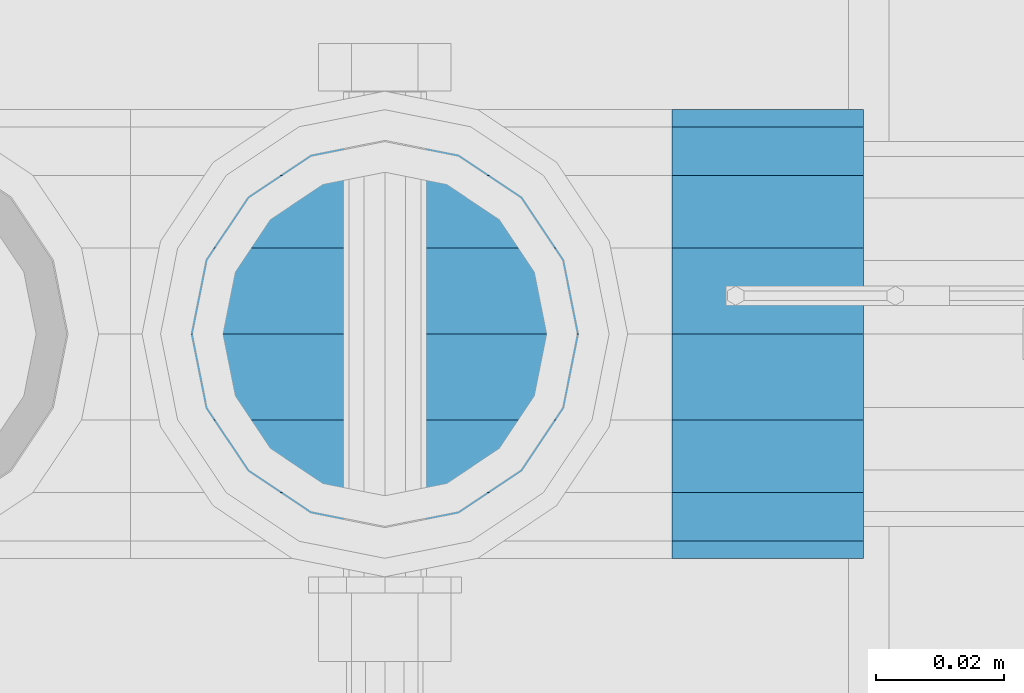
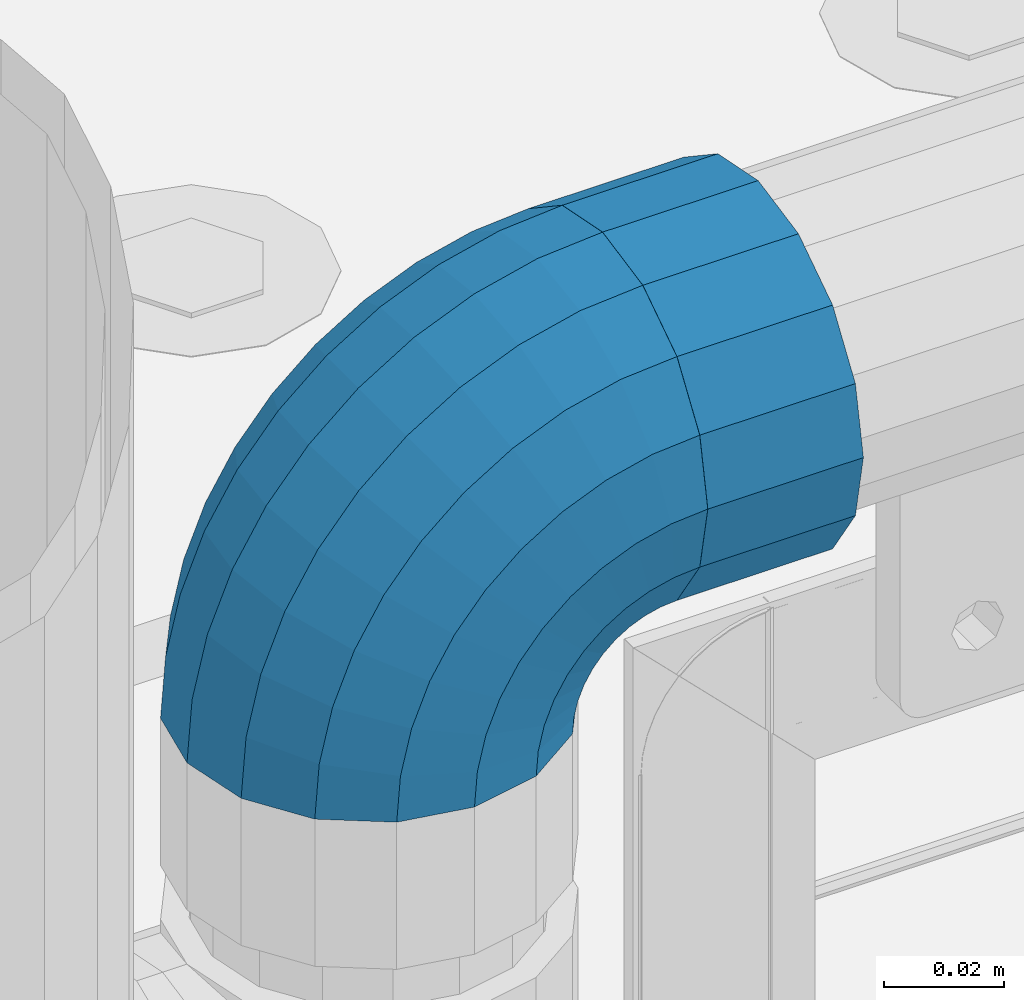
# One storey, part 110 of 193: 1 beam, 1 member.
"""IFC2X3 building model written with IfcOpenShell, lengths in millimetres."""

from ifc_helpers import new_model, si_unit, frame, origin_with_axes, place, context, subcontext, project, spatial, faceted_brep, material, type_object, element, save


model = new_model("IFC2X3")

# Units and contexts
model_context = context("Model", 3, precision=1e-05, world=origin_with_axes())
body_context = subcontext(model_context, "Body", "Model", "MODEL_VIEW")
ifc_project = project(units=[si_unit("LENGTHUNIT", "METRE", prefix="MILLI"), si_unit("AREAUNIT", "SQUARE_METRE"), si_unit("VOLUMEUNIT", "CUBIC_METRE"), si_unit("MASSUNIT", "GRAM", prefix="KILO"), si_unit("TIMEUNIT", "SECOND"), si_unit("PLANEANGLEUNIT", "RADIAN"), si_unit("SOLIDANGLEUNIT", "STERADIAN"), si_unit("THERMODYNAMICTEMPERATUREUNIT", "DEGREE_CELSIUS"), si_unit("LUMINOUSINTENSITYUNIT", "LUMEN")], contexts=[model_context])

# Site, building, storey
site_placement = place(None, origin_with_axes())
site = spatial("IfcSite", under=ifc_project, at=site_placement, CompositionType="ELEMENT")
building_placement = place(site_placement, origin_with_axes())
building = spatial("IfcBuilding", under=site, at=building_placement, Name="Standard", CompositionType="ELEMENT")
storey_placement = place(building_placement, origin_with_axes())
storey = spatial("IfcBuildingStorey", under=building, at=storey_placement, Name="Undefined", CompositionType="ELEMENT", Elevation=0.0)

# Beam
ifc_material = material(Name="Misc_Undefined")
beam_type = type_object("IfcBeamType", PredefinedType="NOTDEFINED")
beam_placement = place(storey_placement, frame((-41784.0, 28664.5, 969.849999999999), z_axis=(0.0, 0.0, 1.0), x_axis=(1.0, 0.0, 0.0)))
element("IfcBeam", 1, at=beam_placement, inside=storey, type_object=beam_type, material=ifc_material, context=body_context, shape_type="Brep", body=[
    faceted_brep([(0.0, -30.3499999999985, 0.0), (0.0, -28.0397438117179, 11.614442172282), (30.0, -28.0397438117179, 11.6144421722805), (30.0, -30.3499999999985, 0.0), (0.0, -21.46069080901, 21.46069080901), (30.0, -21.46069080901, 21.4606908090117), (0.0, -11.614442172282, 28.0397438117179), (30.0, -11.614442172282, 28.0397438117176), (0.0, 0.0, 30.3499999999985), (30.0, 0.0, 30.35), (0.0, 11.614442172282, 28.0397438117179), (30.0, 11.614442172282, 28.0397438117176), (0.0, 21.46069080901, 21.46069080901), (30.0, 21.46069080901, 21.4606908090117), (0.0, 28.0397438117179, 11.614442172282), (30.0, 28.0397438117179, 11.6144421722805), (0.0, 30.3499999999985, 0.0), (30.0, 30.3499999999985, 0.0), (0.0, 28.0397438117179, -11.614442172282), (30.0, 28.0397438117179, -11.6144421722805), (0.0, 21.46069080901, -21.46069080901), (30.0, 21.46069080901, -21.4606908090117), (0.0, 11.614442172282, -28.0397438117179), (30.0, 11.614442172282, -28.0397438117176), (0.0, 0.0, -30.3499999999985), (30.0, 0.0, -30.35), (0.0, -11.614442172282, -28.0397438117179), (30.0, -11.614442172282, -28.0397438117176), (0.0, -21.46069080901, -21.46069080901), (30.0, -21.46069080901, -21.4606908090117), (0.0, -28.0397438117179, -11.614442172282), (30.0, -28.0397438117179, -11.6144421722805), (0.0, -35.1500000000015, 0.0), (0.0, -32.4743655677703, -13.4513226476338), (30.0, -32.4743655677703, -13.4513226476329), (30.0, -35.1500000000015, 0.0), (0.0, -24.8548033587067, -24.8548033587067), (30.0, -24.8548033587067, -24.8548033587072), (0.0, -13.4513226476338, -32.4743655677703), (30.0, -13.4513226476338, -32.4743655677718), (0.0, 0.0, -35.1500000000015), (30.0, 0.0, -35.15), (0.0, 13.4513226476338, -32.4743655677703), (30.0, 13.4513226476338, -32.4743655677718), (0.0, 24.8548033587067, -24.8548033587067), (30.0, 24.8548033587067, -24.8548033587072), (0.0, 32.4743655677703, -13.4513226476338), (30.0, 32.4743655677703, -13.4513226476329), (0.0, 35.1500000000015, 0.0), (30.0, 35.1500000000015, 0.0), (0.0, 32.4743655677703, 13.4513226476338), (30.0, 32.4743655677703, 13.4513226476329), (0.0, 24.8548033587067, 24.8548033587067), (30.0, 24.8548033587067, 24.8548033587072), (0.0, 13.4513226476338, 32.4743655677703), (30.0, 13.4513226476338, 32.4743655677718), (0.0, 0.0, 35.1500000000015), (30.0, 0.0, 35.15), (0.0, -13.4513226476338, 32.4743655677703), (30.0, -13.4513226476338, 32.4743655677718), (0.0, -24.8548033587067, 24.8548033587067), (30.0, -24.8548033587067, 24.8548033587072), (0.0, -32.4743655677703, 13.4513226476338), (30.0, -32.4743655677703, 13.4513226476329)], [[[0, 1, 2, 3]], [[1, 4, 5, 2]], [[4, 6, 7, 5]], [[6, 8, 9, 7]], [[8, 10, 11, 9]], [[10, 12, 13, 11]], [[12, 14, 15, 13]], [[14, 16, 17, 15]], [[16, 18, 19, 17]], [[18, 20, 21, 19]], [[20, 22, 23, 21]], [[22, 24, 25, 23]], [[24, 26, 27, 25]], [[26, 28, 29, 27]], [[28, 30, 31, 29]], [[30, 0, 3, 31]], [[32, 33, 34, 35]], [[33, 36, 37, 34]], [[36, 38, 39, 37]], [[38, 40, 41, 39]], [[40, 42, 43, 41]], [[42, 44, 45, 43]], [[44, 46, 47, 45]], [[46, 48, 49, 47]], [[48, 50, 51, 49]], [[50, 52, 53, 51]], [[52, 54, 55, 53]], [[54, 56, 57, 55]], [[56, 58, 59, 57]], [[58, 60, 61, 59]], [[60, 62, 63, 61]], [[62, 32, 35, 63]], [[37, 39, 41, 43, 45, 47, 49, 51, 53, 55, 57, 59, 61, 63, 35, 34], [5, 7, 9, 11, 13, 15, 17, 19, 21, 23, 25, 27, 29, 31, 3, 2]], [[62, 60, 58, 56, 54, 52, 50, 48, 46, 44, 42, 40, 38, 36, 33, 32], [30, 28, 26, 24, 22, 20, 18, 16, 14, 12, 10, 8, 6, 4, 1, 0]]]),
])

# Member
member_type = type_object("IfcMemberType", PredefinedType="NOTDEFINED")
member_placement = place(storey_placement, frame((-41829.0, 28664.5, 924.849999999999), z_axis=(-0.707106781186548, 0.0, 0.707106781186548), x_axis=(0.707106781186547, 0.0, 0.707106781186548)))
element("IfcMember", 2, at=member_placement, inside=storey, type_object=member_type, material=ifc_material, context=body_context, shape_type="Brep", body=[
    faceted_brep([(0.0, -35.1500000000015, 0.0), (9.51152146007007, -32.4743655677703, -9.51152146007007), (13.2759578763398, -32.4743655677703, -6.2963890252795), (5.36946880023243, -35.1500000000015, 4.58595959347804), (17.5749999999971, -24.8548033587067, -17.5750000000007), (19.978755663109, -24.8548033587067, -15.5219987155651), (22.9628441077002, -13.4513226476338, -22.9628441077002), (24.4574219585229, -13.4513226476338, -21.6863540323939), (24.8548033587067, 0.0, -24.8548033587067), (26.0301204183124, 0.0, -23.850987758804), (22.9628441077002, 13.4513226476338, -22.9628441077002), (24.4574219585229, 13.4513226476338, -21.6863540323939), (17.5749999999971, 24.8548033587067, -17.5750000000007), (19.978755663109, 24.8548033587067, -15.5219987155651), (9.51152146007007, 32.4743655677703, -9.51152146007007), (13.2759578763398, 32.4743655677703, -6.2963890252795), (0.0, 35.1500000000015, 0.0), (5.36946880023243, 35.1500000000015, 4.58595959347804), (-9.51152146007007, 32.4743655677703, 9.51152146007007), (-2.53702027587133, 32.4743655677703, 15.4683082122356), (-17.5750000000007, 24.8548033587067, 17.5750000000007), (-9.23981806264419, 24.8548033587067, 24.6939179025212), (-22.9628441077039, 13.4513226476338, 22.9628441077002), (-13.718484358058, 13.4513226476338, 30.8582732193499), (-24.8548033587103, 0.0, 24.8548033587067), (-15.2911828178476, 0.0, 33.02290694576), (-22.9628441077039, -13.4513226476338, 22.9628441077002), (-13.718484358058, -13.4513226476338, 30.8582732193499), (-17.5750000000007, -24.8548033587067, 17.5750000000007), (-9.23981806264419, -24.8548033587067, 24.6939179025212), (-9.51152146007007, -32.4743655677703, 9.51152146007007), (-2.53702027587133, -32.4743655677703, 15.4683082122356), (0.0, -30.3499999999985, 0.0), (-8.2126508197216, -28.0397438117179, 8.21265081971796), (-1.45732902223972, -28.0397438117179, 13.9822406910389), (5.36946880023243, -30.3499999999985, 4.58595959347804), (-15.1749999999993, -21.46069080901, 15.1749999999993), (-7.24480876131565, -21.46069080901, 21.9480231689959), (-19.827092992, -11.614442172282, 19.827092992), (-11.1118790903529, -11.614442172282, 27.2705888550809), (-21.4606908090136, 0.0, 21.46069080901), (-12.4698136068437, 0.0, 29.139625372758), (-19.827092992, 11.614442172282, 19.827092992), (-11.1118790903529, 11.614442172282, 27.2705888550809), (-15.1749999999993, 21.46069080901, 15.1749999999993), (-7.24480876131565, 21.46069080901, 21.9480231689959), (-8.2126508197216, 28.0397438117179, 8.21265081971796), (-1.45732902223972, 28.0397438117179, 13.9822406910389), (0.0, 30.3499999999985, 0.0), (5.36946880023243, 30.3499999999985, 4.58595959347804), (8.21265081971796, 28.0397438117179, -8.2126508197216), (12.1962666227009, 28.0397438117179, -4.81032150408282), (15.1749999999956, 21.46069080901, -15.1749999999993), (17.9837463617769, 21.46069080901, -12.7761039820398), (19.8270929919963, 11.614442172282, -19.827092992), (21.8508166908177, 11.614442172282, -18.0986696681211), (21.46069080901, 0.0, -21.46069080901), (23.2087512073085, 0.0, -19.9677061858019), (19.8270929919963, -11.614442172282, -19.827092992), (21.8508166908177, -11.614442172282, -18.0986696681211), (15.1749999999956, -21.46069080901, -15.1749999999993), (17.9837463617769, -21.46069080901, -12.7761039820398), (8.21265081971796, -28.0397438117179, -8.2126508197216), (12.1962666227009, -28.0397438117179, -4.81032150408282), (17.4970053560683, -32.4743655677703, -3.70972780292141), (11.3902326651114, -35.1500000000015, 8.27548843508339), (22.6740772628618, -24.8548033587067, -13.8703035149447), (26.1332861179508, -13.4513226476338, -20.6593831546779), (27.3479987309584, 0.0, -23.0433908901396), (26.1332861179508, 13.4513226476338, -20.6593831546779), (22.6740772628618, 24.8548033587067, -13.8703035149447), (17.4970053560683, 32.4743655677703, -3.70972780292141), (11.3902326651114, 35.1500000000015, 8.27548843508339), (5.28345997415818, 32.4743655677703, 20.2607046730882), (0.106388067368243, 24.8548033587067, 30.4212803851115), (-3.35282078772434, 13.4513226476338, 37.2103600248483), (-4.56753340073192, 0.0, 39.5943677603027), (-3.35282078772434, -13.4513226476338, 37.2103600248483), (0.106388067368243, -24.8548033587067, 30.4212803851115), (5.28345997415818, -32.4743655677703, 20.2607046730882), (6.11738625912403, -28.0397438117179, 18.6240321853948), (11.3902326651114, -30.3499999999985, 8.27548843508339), (1.6472829199738, -21.46069080901, 27.3971039594981), (-1.3395446405375, -11.614442172282, 33.259083107896), (-2.38837900198268, 0.0, 35.3175364441995), (-1.3395446405375, 11.614442172282, 33.259083107896), (1.6472829199738, 21.46069080901, 27.3971039594981), (6.11738625912403, 28.0397438117179, 18.6240321853948), (11.3902326651114, 30.3499999999985, 8.27548843508339), (16.6630790711024, 28.0397438117179, -2.07305531522434), (21.1331824102526, 21.46069080901, -10.8461270893349), (24.1200099707639, 11.614442172282, -16.7081062377292), (25.1688443322091, 0.0, -18.7665595740327), (24.1200099707639, -11.614442172282, -16.7081062377292), (21.1331824102526, -21.46069080901, -10.8461270893349), (16.6630790711024, -28.0397438117179, -2.07305531522434), (22.070727701459, -32.4743655677703, -1.81522997693173), (17.9140404065183, -35.1500000000015, 10.9777380798878), (25.5945970362081, -24.8548033587067, -12.6605846156453), (27.9491712485069, -13.4513226476338, -19.9072189058934), (28.7759877587996, 0.0, -22.4518984678871), (27.9491712485069, 13.4513226476338, -19.9072189058934), (25.5945970362081, 24.8548033587067, -12.6605846156453), (22.070727701459, 32.4743655677703, -1.81522997693173), (17.9140404065183, 35.1500000000015, 10.9777380798878), (13.7573531115813, 32.4743655677703, 23.7707061367037), (10.2334837768358, 24.8548033587067, 34.6160607754209), (7.87890956453339, 13.4513226476338, 41.8626950656653), (7.05209305424069, 0.0, 44.407374627659), (7.87890956453339, -13.4513226476338, 41.8626950656653), (10.2334837768358, -24.8548033587067, 34.6160607754209), (13.7573531115813, -32.4743655677703, 23.7707061367037), (14.3249803951003, -28.0397438117179, 22.0237289909674), (17.9140404065183, -30.3499999999985, 10.9777380798878), (11.2823222355109, -21.46069080901, 31.3880679179965), (9.24928305077992, -11.614442172282, 37.6451191472661), (8.53537462723762, 0.0, 39.8423033494473), (9.24928305077992, 11.614442172282, 37.6451191472661), (11.2823222355109, 21.46069080901, 31.3880679179965), (14.3249803951003, 28.0397438117179, 22.0237289909674), (17.9140404065183, 30.3499999999985, 10.9777380798878), (21.50310041794, 28.0397438117179, -0.0682528311917849), (24.545758577533, 21.46069080901, -9.43259175821731), (26.5787977622604, 11.614442172282, -15.6896429874942), (27.2927061858027, 0.0, -17.8868271896717), (26.5787977622604, -11.614442172282, -15.6896429874942), (24.545758577533, -21.46069080901, -9.43259175821731), (21.50310041794, -28.0397438117179, -0.0682528311917849), (26.8845046890456, -32.4743655677703, -0.659544371261291), (24.7802542265854, -35.1500000000015, 12.6261701733893), (28.6684020936846, -24.8548033587067, -11.9226293117936), (29.8603642316994, -13.4513226476338, -19.4483820661262), (30.2789256727447, 0.0, -22.0910749985305), (29.8603642316994, 13.4513226476338, -19.4483820661262), (28.6684020936846, 24.8548033587067, -11.9226293117936), (26.8845046890456, 32.4743655677703, -0.659544371261291), (24.7802542265854, 35.1500000000015, 12.6261701733893), (22.6760037641179, 32.4743655677703, 25.9118847180362), (20.8921063594826, 24.8548033587067, 37.1749696585684), (19.7001442214678, 13.4513226476338, 44.7007224129011), (19.2815827804188, 0.0, 47.3434153453054), (19.7001442214678, -13.4513226476338, 44.7007224129011), (20.8921063594826, -24.8548033587067, 37.1749696585684), (22.6760037641179, -32.4743655677703, 25.9118847180362), (22.963355178621, -28.0397438117179, 24.0976192894668), (24.7802542265854, -30.3499999999985, 12.6261701733893), (21.4230625404816, -21.46069080901, 33.8226442665655), (20.3938719035323, -11.614442172282, 40.3206982094962), (20.032468212612, 0.0, 42.6025113104479), (20.3938719035323, 11.614442172282, 40.3206982094962), (21.4230625404816, 21.46069080901, 33.8226442665655), (22.963355178621, 28.0397438117179, 24.0976192894668), (24.7802542265854, 30.3499999999985, 12.6261701733893), (26.5971532745461, 28.0397438117179, 1.15472105730805), (28.1374459126819, 21.46069080901, -8.5703039197906), (29.1666365496349, 11.614442172282, -15.0683578627213), (29.5280402405551, 0.0, -17.3501709636766), (29.1666365496349, -11.614442172282, -15.0683578627213), (28.1374459126819, -21.46069080901, -8.5703039197906), (26.5971532745461, -28.0397438117179, 1.15472105730805), (31.8198051533946, -32.4743655677703, -0.271127801028342), (31.8198051533946, -35.1500000000015, 13.1801948466054), (31.8198051533946, -24.8548033587067, -11.6746085121013), (31.8198051533946, -13.4513226476338, -19.2941707211648), (31.8198051533909, 0.0, -21.969805153396), (31.8198051533946, 13.4513226476338, -19.2941707211648), (31.8198051533946, 24.8548033587067, -11.6746085121013), (31.8198051533946, 32.4743655677703, -0.271127801028342), (31.8198051533946, 35.1500000000015, 13.1801948466054), (31.8198051533946, 32.4743655677703, 26.6315174942392), (31.8198051533909, 24.8548033587067, 38.0349982053121), (31.8198051533946, 13.4513226476338, 45.6545604143794), (31.8198051533946, 0.0, 48.3301948466069), (31.8198051533946, -13.4513226476338, 45.6545604143794), (31.8198051533909, -24.8548033587067, 38.0349982053121), (31.8198051533946, -32.4743655677703, 26.6315174942392), (31.8198051533909, -28.0397438117179, 24.7946370188874), (31.8198051533946, -30.3499999999985, 13.1801948466054), (31.8198051533946, -21.46069080901, 34.6408856556154), (31.8198051533946, -11.614442172282, 41.219938658327), (31.8198051533909, 0.0, 43.530194846604), (31.8198051533946, 11.614442172282, 41.219938658327), (31.8198051533946, 21.46069080901, 34.6408856556154), (31.8198051533909, 28.0397438117179, 24.7946370188874), (31.8198051533946, 30.3499999999985, 13.1801948466054), (31.8198051533946, 28.0397438117179, 1.56575267432709), (31.8198051533909, 21.46069080901, -8.28049596240453), (31.8198051533946, 11.614442172282, -14.8595489651125), (31.8198051533909, 0.0, -17.1698051533931), (31.8198051533946, -11.614442172282, -14.8595489651125), (31.8198051533909, -21.46069080901, -8.28049596240453), (31.8198051533946, -28.0397438117179, 1.56575267432709), (36.7551056177363, -32.4743655677703, -0.659544371264928), (38.8593560802037, -35.1500000000015, 12.6261701733893), (34.9712082131009, -24.8548033587067, -11.9226293117936), (33.7792460750898, -13.4513226476338, -19.4483820661226), (33.3606846340372, 0.0, -22.0910749985305), (33.7792460750898, 13.4513226476338, -19.4483820661226), (34.9712082131009, 24.8548033587067, -11.9226293117936), (36.7551056177363, 32.4743655677703, -0.659544371264928), (38.8593560802037, 35.1500000000015, 12.6261701733893), (40.9636065426712, 32.4743655677703, 25.9118847180362), (42.7475039473065, 24.8548033587067, 37.1749696585684), (43.9394660853177, 13.4513226476338, 44.7007224128974), (44.3580275263666, 0.0, 47.343415345309), (43.9394660853177, -13.4513226476338, 44.7007224128974), (42.7475039473065, -24.8548033587067, 37.1749696585684), (40.9636065426712, -32.4743655677703, 25.9118847180362), (40.6762551281645, -28.0397438117179, 24.0976192894632), (38.8593560802037, -30.3499999999985, 12.6261701733893), (42.2165477663038, -21.46069080901, 33.8226442665655), (43.2457384032568, -11.614442172282, 40.3206982094962), (43.6071420941771, 0.0, 42.6025113104515), (43.2457384032568, 11.614442172282, 40.3206982094962), (42.2165477663038, 21.46069080901, 33.8226442665655), (40.6762551281645, 28.0397438117179, 24.0976192894632), (38.8593560802037, 30.3499999999985, 12.6261701733893), (37.042457032243, 28.0397438117179, 1.15472105730805), (35.5021643941, 21.46069080901, -8.5703039197906), (34.4729737571543, 11.614442172282, -15.0683578627213), (34.1115700662303, 0.0, -17.3501709636766), (34.4729737571543, -11.614442172282, -15.0683578627213), (35.5021643941, -21.46069080901, -8.5703039197906), (37.042457032243, -28.0397438117179, 1.15472105730805), (41.5688826053265, -32.4743655677703, -1.81522997693173), (45.7255699002671, -35.1500000000015, 10.9777380798878), (38.0450132705773, -24.8548033587067, -12.6605846156453), (35.6904390582786, -13.4513226476338, -19.9072189058897), (34.8636225479859, 0.0, -22.4518984678834), (35.6904390582786, 13.4513226476338, -19.9072189058897), (38.0450132705773, 24.8548033587067, -12.6605846156453), (41.5688826053265, 32.4743655677703, -1.81522997693173), (45.7255699002671, 35.1500000000015, 10.9777380798878), (49.8822571952041, 32.4743655677703, 23.7707061367073), (53.4061265299533, 24.8548033587067, 34.6160607754173), (55.7607007422557, 13.4513226476338, 41.862695065669), (56.5875172525448, 0.0, 44.4073746276626), (55.7607007422557, -13.4513226476338, 41.862695065669), (53.4061265299533, -24.8548033587067, 34.6160607754173), (49.8822571952041, -32.4743655677703, 23.7707061367073), (49.3146299116852, -28.0397438117179, 22.0237289909674), (45.7255699002671, -30.3499999999985, 10.9777380798878), (52.3572880712782, -21.46069080901, 31.3880679179929), (54.3903272560092, -11.614442172282, 37.6451191472697), (55.1042356795442, 0.0, 39.8423033494437), (54.3903272560092, 11.614442172282, 37.6451191472697), (52.3572880712782, 21.46069080901, 31.3880679179929), (49.3146299116852, 28.0397438117179, 22.0237289909674), (45.7255699002671, 30.3499999999985, 10.9777380798878), (42.1365098888455, 28.0397438117179, -0.0682528311954229), (39.0938517292525, 21.46069080901, -9.43259175821731), (37.0608125445215, 11.614442172282, -15.6896429874905), (36.3469041209864, 0.0, -17.8868271896681), (37.0608125445215, -11.614442172282, -15.6896429874905), (39.0938517292525, -21.46069080901, -9.43259175821731), (42.1365098888455, -28.0397438117179, -0.0682528311954229), (46.1426049507172, -32.4743655677703, -3.70972780292141), (52.2493776416704, -35.1500000000015, 8.27548843508339), (40.9655330439236, -24.8548033587067, -13.8703035149447), (37.5063241888347, -13.4513226476338, -20.6593831546816), (36.2916115758235, 0.0, -23.0433908901359), (37.5063241888347, 13.4513226476338, -20.6593831546816), (40.9655330439236, 24.8548033587067, -13.8703035149447), (46.1426049507172, 32.4743655677703, -3.70972780292141), (52.2493776416704, 35.1500000000015, 8.27548843508339), (58.3561503326309, 32.4743655677703, 20.2607046730882), (63.5332222394209, 24.8548033587067, 30.4212803851115), (66.9924310945134, 13.4513226476338, 37.2103600248447), (68.2071437075174, 0.0, 39.5943677603027), (66.9924310945134, -13.4513226476338, 37.2103600248447), (63.5332222394209, -24.8548033587067, 30.4212803851115), (58.3561503326309, -32.4743655677703, 20.2607046730882), (57.5222240476651, -28.0397438117179, 18.6240321853911), (52.2493776416704, -30.3499999999985, 8.27548843508339), (61.9923273868117, -21.46069080901, 27.3971039595017), (64.9791549473193, -11.614442172282, 33.259083107896), (66.0279893087682, 0.0, 35.3175364441995), (64.9791549473193, 11.614442172282, 33.259083107896), (61.9923273868117, 21.46069080901, 27.3971039595017), (57.5222240476651, 28.0397438117179, 18.6240321853911), (52.2493776416704, 30.3499999999985, 8.27548843508339), (46.9765312356831, 28.0397438117179, -2.07305531522798), (42.5064278965328, 21.46069080901, -10.8461270893386), (39.5196003360215, 11.614442172282, -16.7081062377292), (38.4707659745764, 0.0, -18.7665595740364), (39.5196003360215, -11.614442172282, -16.7081062377292), (42.5064278965328, -21.46069080901, -10.8461270893386), (46.9765312356831, -28.0397438117179, -2.07305531522798), (50.3636524304493, -32.4743655677703, -6.29638902527586), (58.2701415065567, -35.1500000000015, 4.58595959347804), (43.6608546436801, -24.8548033587067, -15.5219987155615), (39.1821883482626, -13.4513226476338, -21.6863540323939), (37.6094898884767, 0.0, -23.8509877588003), (39.1821883482626, 13.4513226476338, -21.6863540323939), (43.6608546436801, 24.8548033587067, -15.5219987155615), (50.3636524304493, 32.4743655677703, -6.29638902527586), (58.2701415065567, 35.1500000000015, 4.58595959347804), (66.1766305826604, 32.4743655677703, 15.4683082122319), (72.8794283694333, 24.8548033587067, 24.6939179025212), (77.3580946648435, 13.4513226476338, 30.8582732193499), (78.9307931246331, 0.0, 33.0229069457564), (77.3580946648435, -13.4513226476338, 30.8582732193499), (72.8794283694333, -24.8548033587067, 24.6939179025212), (66.1766305826604, -32.4743655677703, 15.4683082122319), (65.0969393290252, -28.0397438117179, 13.9822406910425), (58.2701415065567, -30.3499999999985, 4.58595959347804), (70.8844190680975, -21.46069080901, 21.9480231689959), (74.751489397142, -11.614442172282, 27.2705888550772), (76.1094239136291, 0.0, 29.1396253727617), (74.751489397142, 11.614442172282, 27.2705888550772), (70.8844190680975, 21.46069080901, 21.9480231689959), (65.0969393290252, 28.0397438117179, 13.9822406910425), (58.2701415065567, 30.3499999999985, 4.58595959347804), (51.4433436840845, 28.0397438117179, -4.81032150407918), (45.6558639450086, 21.46069080901, -12.7761039820361), (41.7887936159677, 11.614442172282, -18.0986696681211), (40.4308590994769, 0.0, -19.9677061857983), (41.7887936159677, -11.614442172282, -18.0986696681211), (45.6558639450086, -21.46069080901, -12.7761039820361), (51.4433436840845, -28.0397438117179, -4.81032150407918), (54.128088846719, -32.4743655677703, -9.51152146007007), (63.6396103067891, -35.1500000000015, 0.0), (46.0646103067884, -24.8548033587067, -17.5750000000007), (40.6767661990889, -13.4513226476338, -22.9628441077002), (38.7848069480824, 0.0, -24.8548033587067), (40.6767661990889, 13.4513226476338, -22.9628441077002), (46.0646103067884, 24.8548033587067, -17.5750000000007), (54.128088846719, 32.4743655677703, -9.51152146007007), (63.6396103067891, 35.1500000000015, 0.0), (73.1511317668592, 32.4743655677703, 9.51152146007007), (81.2146103067898, 24.8548033587067, 17.5750000000007), (86.602454414493, 13.4513226476338, 22.9628441077039), (88.4944136654958, 0.0, 24.8548033587067), (86.602454414493, -13.4513226476338, 22.9628441077039), (81.2146103067898, -24.8548033587067, 17.5750000000007), (73.1511317668592, -32.4743655677703, 9.51152146007007), (71.8522611265071, -28.0397438117179, 8.21265081971796), (63.6396103067891, -30.3499999999985, 0.0), (78.8146103067884, -21.46069080901, 15.1749999999993), (83.4667032987891, -11.614442172282, 19.827092992), (85.1003011158027, 0.0, 21.4606908090136), (83.4667032987891, 11.614442172282, 19.827092992), (78.8146103067884, 21.46069080901, 15.1749999999993), (71.8522611265071, 28.0397438117179, 8.21265081971796), (63.6396103067891, 30.3499999999985, 0.0), (55.4269594870711, 28.0397438117179, -8.21265081971796), (48.4646103067898, 21.46069080901, -15.1749999999993), (43.8125173147891, 11.614442172282, -19.8270929919963), (42.1789194977791, 0.0, -21.46069080901), (43.8125173147891, -11.614442172282, -19.8270929919963), (48.4646103067898, -21.46069080901, -15.1749999999993), (55.4269594870711, -28.0397438117179, -8.21265081971796)], [[[0, 1, 2, 3]], [[1, 4, 5, 2]], [[4, 6, 7, 5]], [[6, 8, 9, 7]], [[8, 10, 11, 9]], [[10, 12, 13, 11]], [[12, 14, 15, 13]], [[14, 16, 17, 15]], [[16, 18, 19, 17]], [[18, 20, 21, 19]], [[20, 22, 23, 21]], [[22, 24, 25, 23]], [[24, 26, 27, 25]], [[26, 28, 29, 27]], [[28, 30, 31, 29]], [[30, 0, 3, 31]], [[32, 33, 34, 35]], [[33, 36, 37, 34]], [[36, 38, 39, 37]], [[38, 40, 41, 39]], [[40, 42, 43, 41]], [[42, 44, 45, 43]], [[44, 46, 47, 45]], [[46, 48, 49, 47]], [[48, 50, 51, 49]], [[50, 52, 53, 51]], [[52, 54, 55, 53]], [[54, 56, 57, 55]], [[56, 58, 59, 57]], [[58, 60, 61, 59]], [[60, 62, 63, 61]], [[62, 32, 35, 63]], [[30, 28, 26, 24, 22, 20, 18, 16, 14, 12, 10, 8, 6, 4, 1, 0], [62, 60, 58, 56, 54, 52, 50, 48, 46, 44, 42, 40, 38, 36, 33, 32]], [[3, 2, 64, 65]], [[2, 5, 66, 64]], [[5, 7, 67, 66]], [[7, 9, 68, 67]], [[9, 11, 69, 68]], [[11, 13, 70, 69]], [[13, 15, 71, 70]], [[15, 17, 72, 71]], [[17, 19, 73, 72]], [[19, 21, 74, 73]], [[21, 23, 75, 74]], [[23, 25, 76, 75]], [[25, 27, 77, 76]], [[27, 29, 78, 77]], [[29, 31, 79, 78]], [[31, 3, 65, 79]], [[35, 34, 80, 81]], [[34, 37, 82, 80]], [[37, 39, 83, 82]], [[39, 41, 84, 83]], [[41, 43, 85, 84]], [[43, 45, 86, 85]], [[45, 47, 87, 86]], [[47, 49, 88, 87]], [[49, 51, 89, 88]], [[51, 53, 90, 89]], [[53, 55, 91, 90]], [[55, 57, 92, 91]], [[57, 59, 93, 92]], [[59, 61, 94, 93]], [[61, 63, 95, 94]], [[63, 35, 81, 95]], [[65, 64, 96, 97]], [[64, 66, 98, 96]], [[66, 67, 99, 98]], [[67, 68, 100, 99]], [[68, 69, 101, 100]], [[69, 70, 102, 101]], [[70, 71, 103, 102]], [[71, 72, 104, 103]], [[72, 73, 105, 104]], [[73, 74, 106, 105]], [[74, 75, 107, 106]], [[75, 76, 108, 107]], [[76, 77, 109, 108]], [[77, 78, 110, 109]], [[78, 79, 111, 110]], [[79, 65, 97, 111]], [[81, 80, 112, 113]], [[80, 82, 114, 112]], [[82, 83, 115, 114]], [[83, 84, 116, 115]], [[84, 85, 117, 116]], [[85, 86, 118, 117]], [[86, 87, 119, 118]], [[87, 88, 120, 119]], [[88, 89, 121, 120]], [[89, 90, 122, 121]], [[90, 91, 123, 122]], [[91, 92, 124, 123]], [[92, 93, 125, 124]], [[93, 94, 126, 125]], [[94, 95, 127, 126]], [[95, 81, 113, 127]], [[97, 96, 128, 129]], [[96, 98, 130, 128]], [[98, 99, 131, 130]], [[99, 100, 132, 131]], [[100, 101, 133, 132]], [[101, 102, 134, 133]], [[102, 103, 135, 134]], [[103, 104, 136, 135]], [[104, 105, 137, 136]], [[105, 106, 138, 137]], [[106, 107, 139, 138]], [[107, 108, 140, 139]], [[108, 109, 141, 140]], [[109, 110, 142, 141]], [[110, 111, 143, 142]], [[111, 97, 129, 143]], [[113, 112, 144, 145]], [[112, 114, 146, 144]], [[114, 115, 147, 146]], [[115, 116, 148, 147]], [[116, 117, 149, 148]], [[117, 118, 150, 149]], [[118, 119, 151, 150]], [[119, 120, 152, 151]], [[120, 121, 153, 152]], [[121, 122, 154, 153]], [[122, 123, 155, 154]], [[123, 124, 156, 155]], [[124, 125, 157, 156]], [[125, 126, 158, 157]], [[126, 127, 159, 158]], [[127, 113, 145, 159]], [[129, 128, 160, 161]], [[128, 130, 162, 160]], [[130, 131, 163, 162]], [[131, 132, 164, 163]], [[132, 133, 165, 164]], [[133, 134, 166, 165]], [[134, 135, 167, 166]], [[135, 136, 168, 167]], [[136, 137, 169, 168]], [[137, 138, 170, 169]], [[138, 139, 171, 170]], [[139, 140, 172, 171]], [[140, 141, 173, 172]], [[141, 142, 174, 173]], [[142, 143, 175, 174]], [[143, 129, 161, 175]], [[145, 144, 176, 177]], [[144, 146, 178, 176]], [[146, 147, 179, 178]], [[147, 148, 180, 179]], [[148, 149, 181, 180]], [[149, 150, 182, 181]], [[150, 151, 183, 182]], [[151, 152, 184, 183]], [[152, 153, 185, 184]], [[153, 154, 186, 185]], [[154, 155, 187, 186]], [[155, 156, 188, 187]], [[156, 157, 189, 188]], [[157, 158, 190, 189]], [[158, 159, 191, 190]], [[159, 145, 177, 191]], [[161, 160, 192, 193]], [[160, 162, 194, 192]], [[162, 163, 195, 194]], [[163, 164, 196, 195]], [[164, 165, 197, 196]], [[165, 166, 198, 197]], [[166, 167, 199, 198]], [[167, 168, 200, 199]], [[168, 169, 201, 200]], [[169, 170, 202, 201]], [[170, 171, 203, 202]], [[171, 172, 204, 203]], [[172, 173, 205, 204]], [[173, 174, 206, 205]], [[174, 175, 207, 206]], [[175, 161, 193, 207]], [[177, 176, 208, 209]], [[176, 178, 210, 208]], [[178, 179, 211, 210]], [[179, 180, 212, 211]], [[180, 181, 213, 212]], [[181, 182, 214, 213]], [[182, 183, 215, 214]], [[183, 184, 216, 215]], [[184, 185, 217, 216]], [[185, 186, 218, 217]], [[186, 187, 219, 218]], [[187, 188, 220, 219]], [[188, 189, 221, 220]], [[189, 190, 222, 221]], [[190, 191, 223, 222]], [[191, 177, 209, 223]], [[193, 192, 224, 225]], [[192, 194, 226, 224]], [[194, 195, 227, 226]], [[195, 196, 228, 227]], [[196, 197, 229, 228]], [[197, 198, 230, 229]], [[198, 199, 231, 230]], [[199, 200, 232, 231]], [[200, 201, 233, 232]], [[201, 202, 234, 233]], [[202, 203, 235, 234]], [[203, 204, 236, 235]], [[204, 205, 237, 236]], [[205, 206, 238, 237]], [[206, 207, 239, 238]], [[207, 193, 225, 239]], [[209, 208, 240, 241]], [[208, 210, 242, 240]], [[210, 211, 243, 242]], [[211, 212, 244, 243]], [[212, 213, 245, 244]], [[213, 214, 246, 245]], [[214, 215, 247, 246]], [[215, 216, 248, 247]], [[216, 217, 249, 248]], [[217, 218, 250, 249]], [[218, 219, 251, 250]], [[219, 220, 252, 251]], [[220, 221, 253, 252]], [[221, 222, 254, 253]], [[222, 223, 255, 254]], [[223, 209, 241, 255]], [[225, 224, 256, 257]], [[224, 226, 258, 256]], [[226, 227, 259, 258]], [[227, 228, 260, 259]], [[228, 229, 261, 260]], [[229, 230, 262, 261]], [[230, 231, 263, 262]], [[231, 232, 264, 263]], [[232, 233, 265, 264]], [[233, 234, 266, 265]], [[234, 235, 267, 266]], [[235, 236, 268, 267]], [[236, 237, 269, 268]], [[237, 238, 270, 269]], [[238, 239, 271, 270]], [[239, 225, 257, 271]], [[241, 240, 272, 273]], [[240, 242, 274, 272]], [[242, 243, 275, 274]], [[243, 244, 276, 275]], [[244, 245, 277, 276]], [[245, 246, 278, 277]], [[246, 247, 279, 278]], [[247, 248, 280, 279]], [[248, 249, 281, 280]], [[249, 250, 282, 281]], [[250, 251, 283, 282]], [[251, 252, 284, 283]], [[252, 253, 285, 284]], [[253, 254, 286, 285]], [[254, 255, 287, 286]], [[255, 241, 273, 287]], [[257, 256, 288, 289]], [[256, 258, 290, 288]], [[258, 259, 291, 290]], [[259, 260, 292, 291]], [[260, 261, 293, 292]], [[261, 262, 294, 293]], [[262, 263, 295, 294]], [[263, 264, 296, 295]], [[264, 265, 297, 296]], [[265, 266, 298, 297]], [[266, 267, 299, 298]], [[267, 268, 300, 299]], [[268, 269, 301, 300]], [[269, 270, 302, 301]], [[270, 271, 303, 302]], [[271, 257, 289, 303]], [[273, 272, 304, 305]], [[272, 274, 306, 304]], [[274, 275, 307, 306]], [[275, 276, 308, 307]], [[276, 277, 309, 308]], [[277, 278, 310, 309]], [[278, 279, 311, 310]], [[279, 280, 312, 311]], [[280, 281, 313, 312]], [[281, 282, 314, 313]], [[282, 283, 315, 314]], [[283, 284, 316, 315]], [[284, 285, 317, 316]], [[285, 286, 318, 317]], [[286, 287, 319, 318]], [[287, 273, 305, 319]], [[289, 288, 320, 321]], [[288, 290, 322, 320]], [[290, 291, 323, 322]], [[291, 292, 324, 323]], [[292, 293, 325, 324]], [[293, 294, 326, 325]], [[294, 295, 327, 326]], [[295, 296, 328, 327]], [[296, 297, 329, 328]], [[297, 298, 330, 329]], [[298, 299, 331, 330]], [[299, 300, 332, 331]], [[300, 301, 333, 332]], [[301, 302, 334, 333]], [[302, 303, 335, 334]], [[303, 289, 321, 335]], [[305, 304, 336, 337]], [[304, 306, 338, 336]], [[306, 307, 339, 338]], [[307, 308, 340, 339]], [[308, 309, 341, 340]], [[309, 310, 342, 341]], [[310, 311, 343, 342]], [[311, 312, 344, 343]], [[312, 313, 345, 344]], [[313, 314, 346, 345]], [[314, 315, 347, 346]], [[315, 316, 348, 347]], [[316, 317, 349, 348]], [[317, 318, 350, 349]], [[318, 319, 351, 350]], [[319, 305, 337, 351]], [[322, 323, 324, 325, 326, 327, 328, 329, 330, 331, 332, 333, 334, 335, 321, 320], [338, 339, 340, 341, 342, 343, 344, 345, 346, 347, 348, 349, 350, 351, 337, 336]]]),
])

save(model, "model.ifc")
